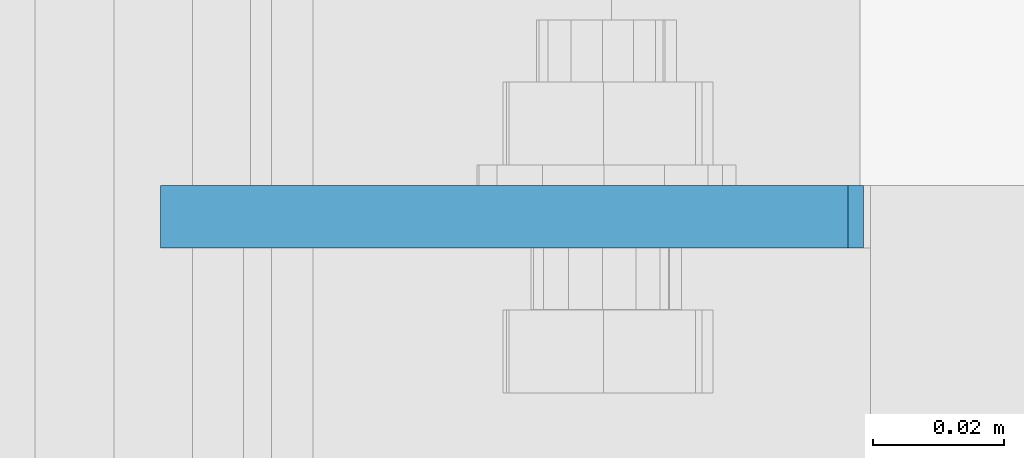
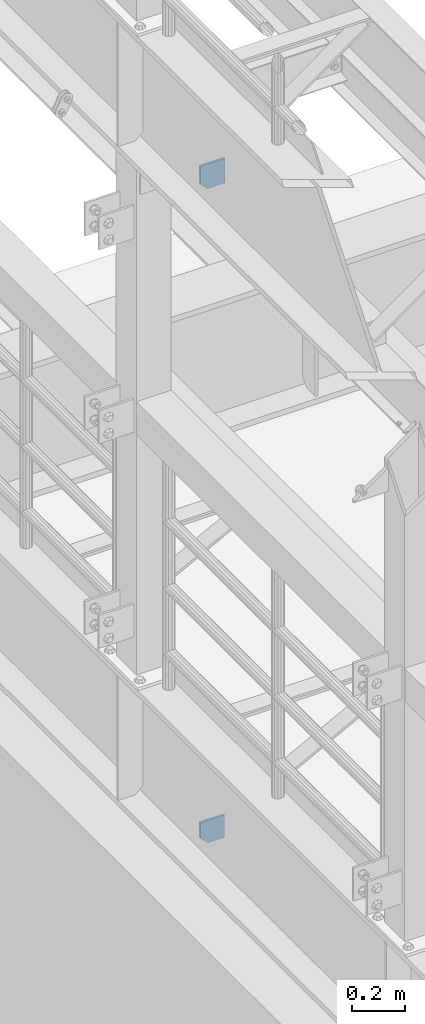
# One storey, part 1622 of 1876: 2 plates, 2 elements without a shape of their own.
"""IFC2X3 building model written with IfcOpenShell, lengths in millimetres."""

from ifc_helpers import new_model, si_unit, frame, origin_with_axes, place, context, subcontext, project, spatial, faceted_brep, material, type_object, element, aggregate, save


model = new_model("IFC2X3")

# Units and contexts
model_context = context("Model", 3, precision=1e-05, world=origin_with_axes())
body_context = subcontext(model_context, "Body", "Model", "MODEL_VIEW")
ifc_project = project(units=[si_unit("LENGTHUNIT", "METRE", prefix="MILLI"), si_unit("AREAUNIT", "SQUARE_METRE"), si_unit("VOLUMEUNIT", "CUBIC_METRE"), si_unit("MASSUNIT", "GRAM", prefix="KILO"), si_unit("TIMEUNIT", "SECOND"), si_unit("PLANEANGLEUNIT", "RADIAN"), si_unit("SOLIDANGLEUNIT", "STERADIAN"), si_unit("THERMODYNAMICTEMPERATUREUNIT", "DEGREE_CELSIUS"), si_unit("LUMINOUSINTENSITYUNIT", "LUMEN")], contexts=[model_context])

# Site, building, storey
site_placement = place(None, origin_with_axes())
site = spatial("IfcSite", under=ifc_project, at=site_placement, CompositionType="ELEMENT")
building_placement = place(site_placement, origin_with_axes())
building = spatial("IfcBuilding", under=site, at=building_placement, Name="Undefined", CompositionType="ELEMENT")
storey_placement = place(building_placement, origin_with_axes())
storey = spatial("IfcBuildingStorey", under=building, at=storey_placement, Name="Undefined", CompositionType="ELEMENT", Elevation=0.0)

# Assembly, plate
assembly_1_placement = place(storey_placement, origin_with_axes())
assembly_1 = element("IfcElementAssembly", 1, at=assembly_1_placement, inside=storey, Name="BEAM", AssemblyPlace="NOTDEFINED", PredefinedType="RIGID_FRAME")
ifc_material = material(Name="STEEL/A36")
plate_type_1 = type_object("IfcPlateType", PredefinedType="NOTDEFINED")
plate_1_placement = place(assembly_1_placement, frame((112.451000275039, 5176.8375, 4637.38699830036), z_axis=(0.0, 0.0, -1.0), x_axis=(-1.0, 0.0, 0.0)))
plate_1 = element("IfcPlate", 2, at=plate_1_placement, type_object=plate_type_1, material=ifc_material, Name="PLATE", context=body_context, shape_type="Brep", body=[
    faceted_brep([(0.0, -4.76249999999982, 0.0), (0.0, -4.76249999999999, 103.486999511719), (0.0, 4.76249999999999, 103.486999511719), (0.0, 4.76249999999982, 0.0), (73.5572509765625, -4.76249999999999, 103.486999511719), (73.5572509765625, 4.76249999999999, 103.486999511719), (105.307250976562, -4.76249999999999, 71.7369995117188), (105.307250976562, 4.76249999999999, 71.7369995117188), (105.307250976562, -4.76249999999999, 0.0), (105.307250976562, 4.76249999999999, 0.0)], [[[0, 1, 2, 3]], [[1, 4, 5, 2]], [[4, 6, 7, 5]], [[6, 8, 9, 7]], [[8, 0, 3, 9]], [[5, 7, 9, 3, 2]], [[8, 6, 4, 1, 0]]]),
])
aggregate(assembly_1, [plate_1])

assembly_2_placement = place(storey_placement, origin_with_axes())
assembly_2 = element("IfcElementAssembly", 3, at=assembly_2_placement, inside=storey, Name="BEAM", AssemblyPlace="NOTDEFINED", PredefinedType="RIGID_FRAME")
plate_type_2 = type_object("IfcPlateType", PredefinedType="NOTDEFINED")
plate_2_placement = place(assembly_2_placement, frame((7.14375, 5176.8375, 7556.5), z_axis=(0.0, 0.0, 1.0), x_axis=(1.0, 0.0, 0.0)))
plate_2 = element("IfcPlate", 4, at=plate_2_placement, type_object=plate_type_2, material=ifc_material, Name="PLATE", context=body_context, shape_type="Brep", body=[
    faceted_brep([(-9.76996261670138e-14, -4.76250000000073, 31.75), (-4.52970994047064e-14, -4.76249999999982, 114.585624694824), (-4.52970994047064e-14, 4.76249999999982, 114.585624694824), (-9.76996261670138e-14, 4.76250000000073, 31.75), (107.66130065918, -4.76249999999982, 114.585624694824), (107.66130065918, 4.76249999999982, 114.585624694824), (107.66130065918, -4.76249999999982, 0.0), (107.66130065918, 4.76249999999982, 0.0), (31.75, -4.76250000000073, 0.0), (31.75, 4.76250000000073, 0.0)], [[[0, 1, 2, 3]], [[1, 4, 5, 2]], [[4, 6, 7, 5]], [[6, 8, 9, 7]], [[8, 0, 3, 9]], [[5, 7, 9, 3, 2]], [[8, 6, 4, 1, 0]]]),
])
aggregate(assembly_2, [plate_2])

save(model, "model.ifc")
